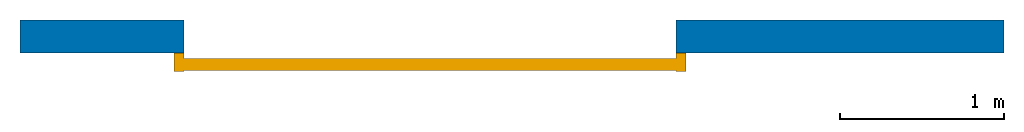
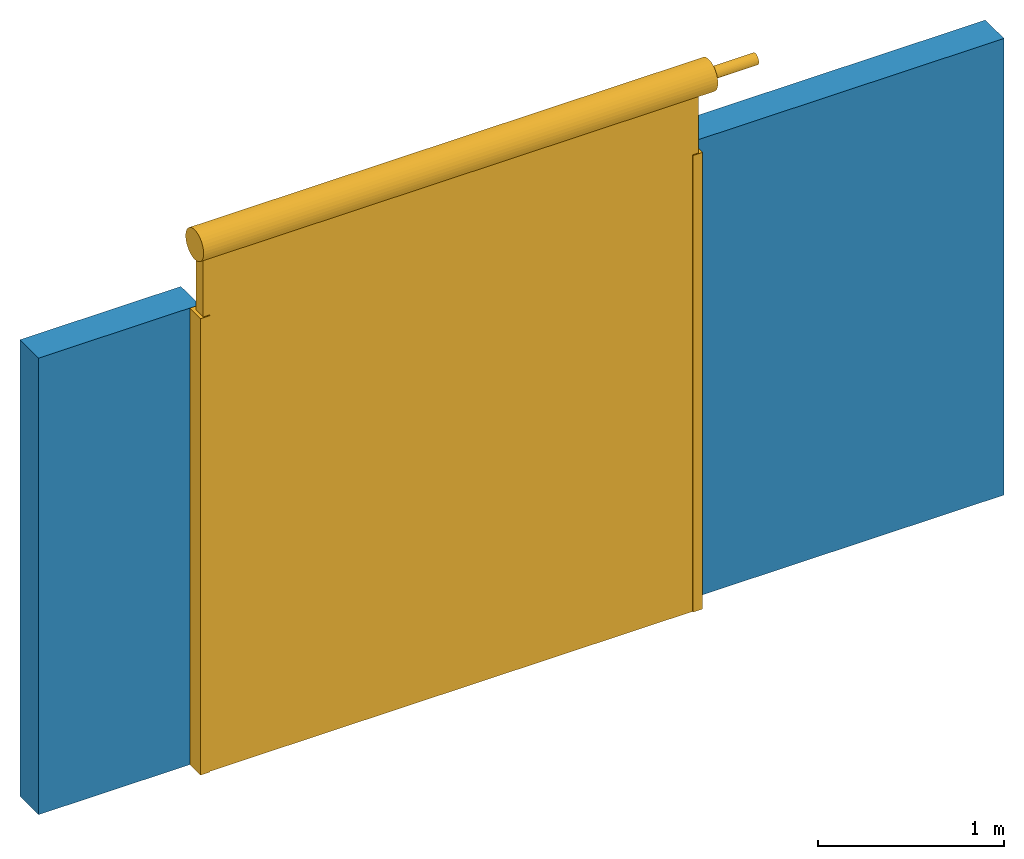
# One storey: 1 door, 1 wall, 1 opening.
"""IFC2X3 building model written with IfcOpenShell, lengths in millimetres."""

from ifc_helpers import new_model, entity, si_unit, converted_unit, derived_unit, direction, frame, frame_2d, origin, origin_2d_with_axis, place, context, subcontext, project, spatial, polyline, rectangle, circle, outline, extrude, faceted_brep, source, transform, mapped, material, material_list, layer, layer_set, layer_usage, type_object, type_shapes, element, fill, save


model = new_model("IFC2X3")

# Units and contexts
model_context = context("Model", 3, precision=0.01, world=origin(), true_north=direction((6.12303176911189e-17, 1.0)))
context_of_model = context(None, 3, precision=0.01, world=origin(), true_north=direction((6.12303176911189e-17, 1.0)))
body_context = subcontext(model_context, "Body", "Model", "MODEL_VIEW")
ifc_project = project(units=[si_unit("LENGTHUNIT", "METRE", prefix="MILLI"), si_unit("AREAUNIT", "SQUARE_METRE"), si_unit("VOLUMEUNIT", "CUBIC_METRE"), converted_unit("PLANEANGLEUNIT", "DEGREE", entity("IfcRatioMeasure", 0.0174532925199433), si_unit("PLANEANGLEUNIT", "RADIAN"), dimensions=[0, 0, 0, 0, 0, 0, 0]), si_unit("MASSUNIT", "GRAM", prefix="KILO"), si_unit("TIMEUNIT", "SECOND"), si_unit("FREQUENCYUNIT", "HERTZ"), si_unit("THERMODYNAMICTEMPERATUREUNIT", "DEGREE_CELSIUS"), derived_unit("THERMALTRANSMITTANCEUNIT", [(si_unit("MASSUNIT", "GRAM", prefix="KILO"), 1), (si_unit("THERMODYNAMICTEMPERATUREUNIT", "KELVIN"), -1), (si_unit("TIMEUNIT", "SECOND"), -3)]), derived_unit("VOLUMETRICFLOWRATEUNIT", [(si_unit("LENGTHUNIT", "METRE"), 3), (si_unit("TIMEUNIT", "SECOND"), -1)]), si_unit("ELECTRICCURRENTUNIT", "AMPERE"), si_unit("ELECTRICVOLTAGEUNIT", "VOLT"), si_unit("POWERUNIT", "WATT"), si_unit("FORCEUNIT", "NEWTON", prefix="KILO"), si_unit("ILLUMINANCEUNIT", "LUX"), si_unit("LUMINOUSFLUXUNIT", "LUMEN"), si_unit("LUMINOUSINTENSITYUNIT", "CANDELA"), si_unit("PRESSUREUNIT", "PASCAL")], contexts=[model_context, context_of_model])

# Site, building, storey
site_placement = place(None, origin())
site = spatial("IfcSite", under=ifc_project, at=site_placement, CompositionType="ELEMENT")
building_placement = place(site_placement, origin())
building = spatial("IfcBuilding", under=site, at=building_placement, CompositionType="ELEMENT")
storey_placement = place(building_placement, origin())
storey = spatial("IfcBuildingStorey", under=building, at=storey_placement, CompositionType="ELEMENT", Elevation=0.0)

# Wall, opening, door
ifc_material_1 = material()
ifc_layer = layer(ifc_material_1, 200.0)
ifc_layer_set = layer_set([ifc_layer])
ifc_layer_usage = layer_usage(ifc_layer_set, "AXIS2", "NEGATIVE", 100.0)
wall_type = type_object("IfcWallType", PredefinedType="STANDARD", material=ifc_layer_set)
wall_placement = place(storey_placement, frame((-30147.0958388037, 10047.082659008, 0.0)))
wall = element("IfcWallStandardCase", 1, at=wall_placement, inside=storey, type_object=wall_type, material=ifc_layer_usage, context=body_context, shape_type="SweptSolid", body=[
    extrude(rectangle(XDim=6000.0, YDim=199.999999999998, at=frame_2d((3000.0, 6.96331881044898e-13), x_axis=(-1.0, 0.0))), origin(), (0.0, 0.0, 1.0), 3000.0),
])
opening_placement = place(wall_placement, frame((620.0, -920.0, 0.0)))
opening = element("IfcOpeningElement", 2, at=opening_placement, cuts=wall, ObjectType="Opening", context=body_context, shape_type="Brep", body=[
    faceted_brep([(3380.0, 1020.0, 3000.0), (380.0, 1020.0, 3000.0), (380.0, 820.0, 3000.0), (0.0, 820.0, 3000.0), (0.0, 0.0, 3000.0), (3980.0, 0.0, 3000.0), (3980.0, 820.0, 3000.0), (3380.0, 820.0, 3000.0), (3380.0, 1020.0, 0.0), (3380.0, 820.0, 0.0), (3980.0, 820.0, 0.0), (3980.0, 0.0, 0.0), (0.0, 0.0, 0.0), (0.0, 820.0, 0.0), (380.0, 820.0, 0.0), (380.0, 1020.0, 0.0)], [[[0, 1, 2, 3, 4, 5, 6, 7]], [[8, 9, 10, 11, 12, 13, 14, 15]], [[1, 0, 8, 15]], [[2, 1, 15, 14]], [[3, 2, 14, 13]], [[4, 3, 13, 12]], [[5, 4, 12, 11]], [[6, 5, 11, 10]], [[7, 6, 10, 9]], [[0, 7, 9, 8]]]),
])
ifc_material_2 = material()
ifc_material_3 = material()
ifc_material_list_1 = material_list([ifc_material_2, ifc_material_3])
ifc_material_list_2 = material_list([ifc_material_2, ifc_material_3])
door_style = type_object("IfcDoorStyle", ConstructionType="NOTDEFINED", OperationType="NOTDEFINED", ParameterTakesPrecedence=False, Sizeable=False, material=ifc_material_list_2)
shared_shape = source(origin(), body_context, "Body", "SweptSolid", [
    extrude(rectangle(XDim=3079.99999999999, YDim=75.0000000000013, at=origin_2d_with_axis()), frame((1880.0, -271.00021132686, 0.0), z_axis=(0.0, 0.0, 1.0), x_axis=(-1.0, 0.0, 0.0)), (0.0, 0.0, 1.0), 3499.99999999997),
    extrude(outline(polyline([(-35.0, -64.2501056634293), (25.0, -64.2501056634293), (25.0, -30.7498943365702), (-15.0, -30.7498943365702), (-15.0, 44.2501056634311), (25.0, 44.2501056634311), (25.0, 50.7498943365683), (-35.0, 50.7498943365683), (-35.0, -64.2501056634293)])), frame((3405.0, -264.250105663429, 0.0), z_axis=(0.0, 0.0, 1.0), x_axis=(-1.0, 0.0, 0.0)), (0.0, 0.0, 1.0), 2999.99999999998),
    extrude(outline(polyline([(-25.0, -64.2501056634293), (35.0, -64.2501056634293), (35.0, 50.7498943365683), (-25.0, 50.7498943365683), (-25.0, 44.2501056634312), (15.0, 44.2501056634312), (15.0, -30.7498943365701), (-25.0, -30.7498943365701), (-25.0, -64.2501056634293)])), frame((355.0, -264.250105663429, 0.0), z_axis=(0.0, 0.0, 1.0), x_axis=(-1.0, 0.0, 0.0)), (0.0, 0.0, 1.0), 2999.99999999998),
    extrude(circle(Radius=35.0000000000001, at=origin_2d_with_axis()), frame((320.0, -315.0, 3500.0), z_axis=(1.0, 0.0, 0.0), x_axis=(0.0, 1.0, 0.0)), (0.0, 0.0, 1.0), 3450.00000000001),
    extrude(circle(Radius=97.0000000000096, at=frame_2d((-3.38395977905748e-14, 0.0), x_axis=(1.0, 0.0))), frame((283.392459677981, -315.0, 3500.0), z_axis=(1.0, 0.0, 0.0), x_axis=(0.0, 1.0, 0.0)), (0.0, 0.0, 1.0), 3196.60754032204),
])
type_shapes(door_style, [shared_shape])
door_placement = place(opening_placement, frame((0.0, 1020.0, 0.0)))
door = element("IfcDoor", 3, at=door_placement, inside=storey, type_object=door_style, material=ifc_material_list_1, OverallHeight=3599.99999999998, OverallWidth=3925.0, context=body_context, shape_type="MappedRepresentation", body=[
    mapped(shared_shape, transform((0.0, 0.0, 0.0), scale=1.0)),
])
fill(opening, door)

save(model, "model.ifc")
